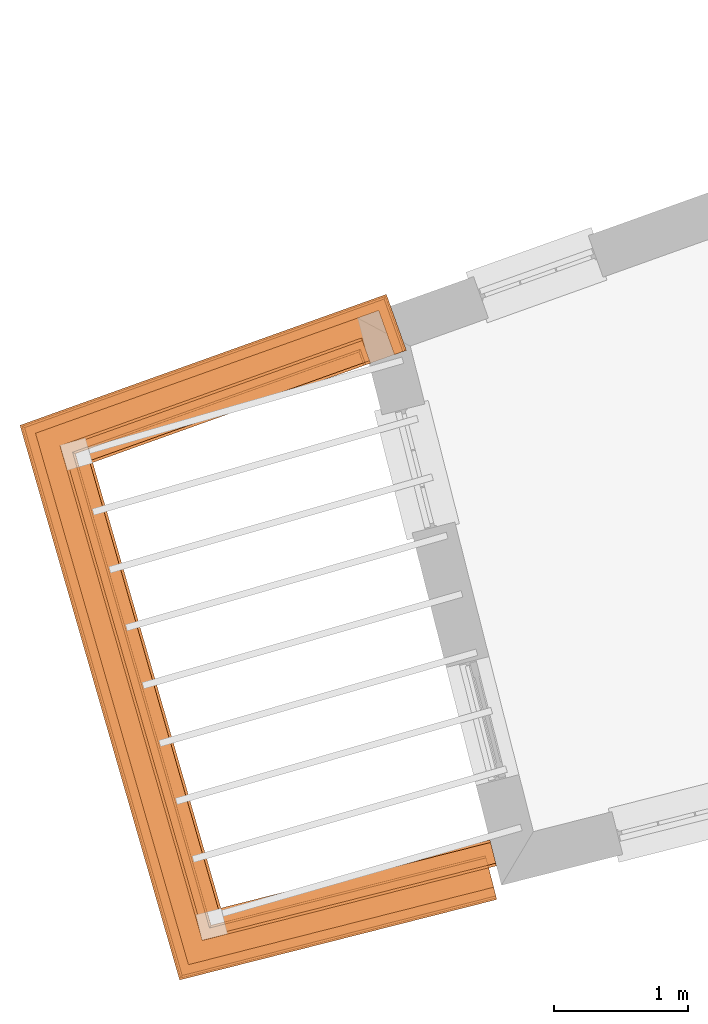
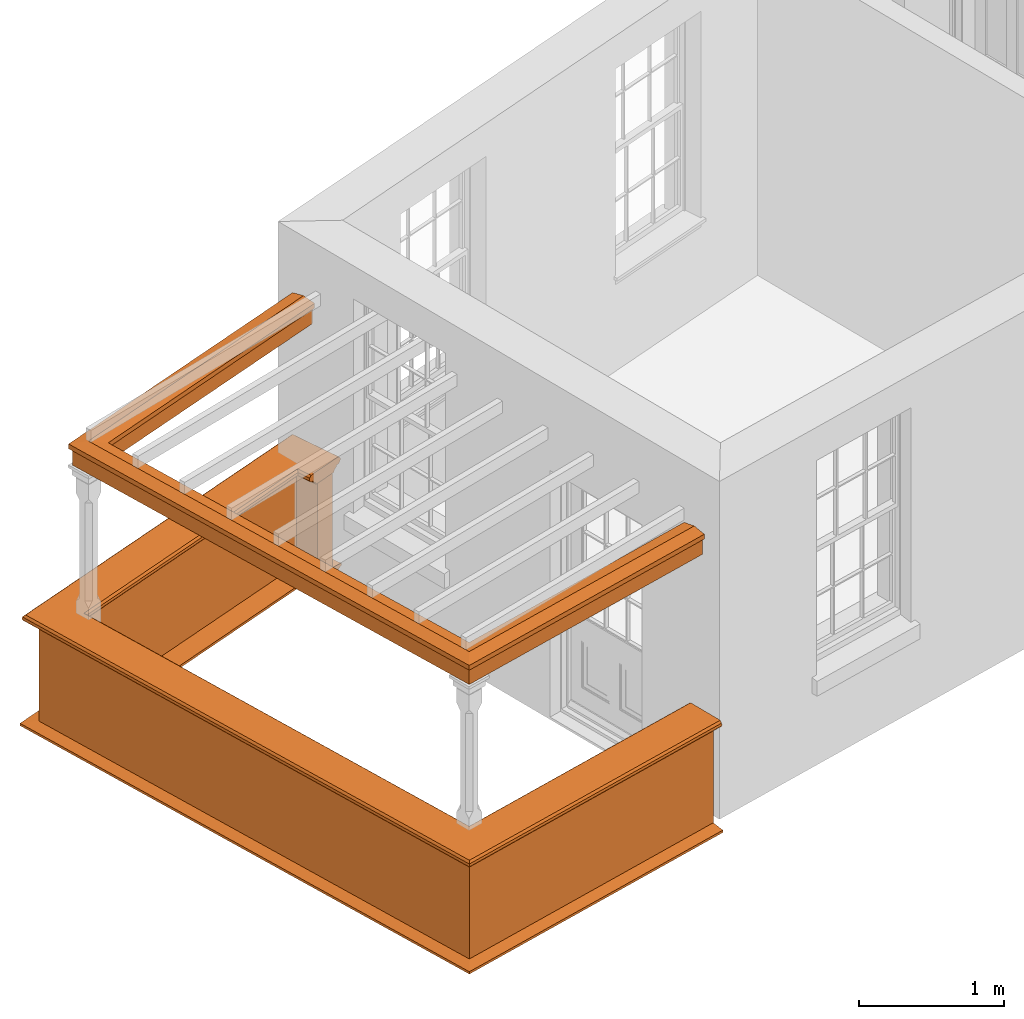
# One storey, part 10 of 11: 5 proxies.
"""IFC2X3 building model written with IfcOpenShell, lengths in metres."""

from ifc_helpers import new_model, entity, si_unit, frame, origin, place, context, subcontext, project, spatial, element, save


model = new_model("IFC2X3")

# Units and contexts
model_context = context("Model", 3, world=origin())
body_context = subcontext(model_context, "Body", "Model", "MODEL_VIEW")
ifc_project = project(units=[si_unit("PLANEANGLEUNIT", "RADIAN"), si_unit("MASSUNIT", "GRAM", prefix="KILO"), si_unit("FORCEUNIT", "NEWTON", prefix="KILO"), si_unit("LENGTHUNIT", "METRE")], contexts=[model_context])

# Site, building, storey
site_placement = place(None, origin())
site = spatial("IfcSite", under=ifc_project, at=site_placement, CompositionType="ELEMENT")
building_placement = place(None, origin())
building = spatial("IfcBuilding", under=site, at=building_placement, Name="Building plot-13", CompositionType="ELEMENT")
storey_placement = place(None, frame((0.0, 0.0, 6.7)))
storey = spatial("IfcBuildingStorey", under=building, at=storey_placement, Name="Floor 1", CompositionType="ELEMENT", Elevation=6.7)

# Proxies
proxy_1_placement = place(storey_placement, origin())
axis2_placement3_d_1 = entity("IfcAxis2Placement3D", entity("IfcCartesianPoint", [0.0, 0.0, 0.0]))
element("IfcBuildingElementProxy", 1, at=proxy_1_placement, inside=storey, Name="parapet", CompositionType="ELEMENT", context=body_context, shape_type="SweptSolid", held_by="IfcProductRepresentation", body=[
    entity("IfcSurfaceCurveSweptAreaSolid", entity("IfcArbitraryClosedProfileDef", "AREA", None, entity("IfcPolyline", [entity("IfcCartesianPoint", [0.0, 0.25]), entity("IfcCartesianPoint", [0.795, 0.25]), entity("IfcCartesianPoint", [0.795, 0.09]), entity("IfcCartesianPoint", [0.02, 0.09]), entity("IfcCartesianPoint", [0.02, -0.08]), entity("IfcCartesianPoint", [0.0, -0.08]), entity("IfcCartesianPoint", [0.0, 0.25])])), axis2_placement3_d_1, entity("IfcPolyline", [entity("IfcCartesianPoint", [65.5529050582027, 47.3924811578515]), entity("IfcCartesianPoint", [65.5192356310196, 47.4866425600987]), entity("IfcCartesianPoint", [63.4113078183222, 46.7329077993252]), entity("IfcCartesianPoint", [64.4222488743234, 43.2198749590139]), entity("IfcCartesianPoint", [66.4683425667329, 43.7388197880005])]), 0.0, 1.0, entity("IfcPlane", axis2_placement3_d_1)),
])
proxy_2_placement = place(storey_placement, origin())
axis2_placement3_d_2 = entity("IfcAxis2Placement3D", entity("IfcCartesianPoint", [0.0, 0.0, 0.0]))
element("IfcBuildingElementProxy", 2, at=proxy_2_placement, inside=storey, Name="parapet", CompositionType="ELEMENT", context=body_context, shape_type="SweptSolid", held_by="IfcProductRepresentation", body=[
    entity("IfcSurfaceCurveSweptAreaSolid", entity("IfcArbitraryClosedProfileDef", "AREA", None, entity("IfcPolyline", [entity("IfcCartesianPoint", [0.795, 0.265]), entity("IfcCartesianPoint", [0.807, 0.268]), entity("IfcCartesianPoint", [0.816, 0.274]), entity("IfcCartesianPoint", [0.822, 0.283]), entity("IfcCartesianPoint", [0.825, 0.295]), entity("IfcCartesianPoint", [0.84, 0.295]), entity("IfcCartesianPoint", [0.84, 0.305]), entity("IfcCartesianPoint", [0.842, 0.317]), entity("IfcCartesianPoint", [0.849, 0.326]), entity("IfcCartesianPoint", [0.858, 0.333]), entity("IfcCartesianPoint", [0.87, 0.335]), entity("IfcCartesianPoint", [0.882, 0.333]), entity("IfcCartesianPoint", [0.891, 0.326]), entity("IfcCartesianPoint", [0.898, 0.317]), entity("IfcCartesianPoint", [0.9, 0.305]), entity("IfcCartesianPoint", [0.9, 0.035]), entity("IfcCartesianPoint", [0.898, 0.023]), entity("IfcCartesianPoint", [0.891, 0.014]), entity("IfcCartesianPoint", [0.882, 0.007]), entity("IfcCartesianPoint", [0.87, 0.005]), entity("IfcCartesianPoint", [0.858, 0.007]), entity("IfcCartesianPoint", [0.849, 0.014]), entity("IfcCartesianPoint", [0.842, 0.023]), entity("IfcCartesianPoint", [0.84, 0.035]), entity("IfcCartesianPoint", [0.84, 0.045]), entity("IfcCartesianPoint", [0.825, 0.045]), entity("IfcCartesianPoint", [0.822, 0.057]), entity("IfcCartesianPoint", [0.816, 0.066]), entity("IfcCartesianPoint", [0.807, 0.072]), entity("IfcCartesianPoint", [0.795, 0.075]), entity("IfcCartesianPoint", [0.795, 0.265])])), axis2_placement3_d_2, entity("IfcPolyline", [entity("IfcCartesianPoint", [65.5529050582027, 47.3924811578515]), entity("IfcCartesianPoint", [65.5192356310196, 47.4866425600987]), entity("IfcCartesianPoint", [63.4113078183222, 46.7329077993252]), entity("IfcCartesianPoint", [64.4222488743234, 43.2198749590139]), entity("IfcCartesianPoint", [66.4683425667329, 43.7388197880005])]), 0.0, 1.0, entity("IfcPlane", axis2_placement3_d_2)),
])
proxy_3_placement = place(storey_placement, origin())
axis2_placement3_d_3 = entity("IfcAxis2Placement3D", entity("IfcCartesianPoint", [0.0, 0.0, 0.0]))
element("IfcBuildingElementProxy", 3, at=proxy_3_placement, inside=storey, Name="parapet", CompositionType="ELEMENT", context=body_context, shape_type="SweptSolid", held_by="IfcProductRepresentation", body=[
    entity("IfcSurfaceCurveSweptAreaSolid", entity("IfcArbitraryClosedProfileDef", "AREA", None, entity("IfcPolyline", [entity("IfcCartesianPoint", [-0.1, 0.25]), entity("IfcCartesianPoint", [-0.1, 0.265]), entity("IfcCartesianPoint", [-0.085, 0.265]), entity("IfcCartesianPoint", [-0.084, 0.278]), entity("IfcCartesianPoint", [-0.081, 0.289]), entity("IfcCartesianPoint", [-0.074, 0.301]), entity("IfcCartesianPoint", [-0.065, 0.309]), entity("IfcCartesianPoint", [-0.055, 0.315]), entity("IfcCartesianPoint", [-0.044, 0.324]), entity("IfcCartesianPoint", [-0.038, 0.334]), entity("IfcCartesianPoint", [-0.035, 0.345]), entity("IfcCartesianPoint", [-0.015, 0.345]), entity("IfcCartesianPoint", [0.0, 0.25]), entity("IfcCartesianPoint", [-0.1, 0.25])])), axis2_placement3_d_3, entity("IfcPolyline", [entity("IfcCartesianPoint", [65.5529050582027, 47.3924811578515]), entity("IfcCartesianPoint", [65.5192356310196, 47.4866425600987]), entity("IfcCartesianPoint", [63.4113078183222, 46.7329077993252]), entity("IfcCartesianPoint", [64.4222488743234, 43.2198749590139]), entity("IfcCartesianPoint", [66.4683425667329, 43.7388197880005])]), 0.0, 1.0, entity("IfcPlane", axis2_placement3_d_3)),
])
proxy_4_placement = place(storey_placement, frame((0.0, 0.0, 2.85)))
axis2_placement3_d_4 = entity("IfcAxis2Placement3D", entity("IfcCartesianPoint", [0.0, 0.0, 0.0]))
element("IfcBuildingElementProxy", 4, at=proxy_4_placement, inside=storey, Name="pergola beam", CompositionType="ELEMENT", context=body_context, shape_type="SweptSolid", held_by="IfcProductRepresentation", body=[
    entity("IfcSurfaceCurveSweptAreaSolid", entity("IfcArbitraryClosedProfileDef", "AREA", None, entity("IfcPolyline", [entity("IfcCartesianPoint", [-0.7, -0.08]), entity("IfcCartesianPoint", [-0.7, 0.08]), entity("IfcCartesianPoint", [-0.56, 0.08]), entity("IfcCartesianPoint", [-0.56, -0.08]), entity("IfcCartesianPoint", [-0.7, -0.08])])), axis2_placement3_d_4, entity("IfcPolyline", [entity("IfcCartesianPoint", [65.5757324723679, 47.5068442164086]), entity("IfcCartesianPoint", [63.4113078183222, 46.7329077993252]), entity("IfcCartesianPoint", [64.4222488743234, 43.2198749590139]), entity("IfcCartesianPoint", [66.5265011434384, 43.7535703797034])]), 0.0, 1.0, entity("IfcPlane", axis2_placement3_d_4)),
])
proxy_5_placement = place(storey_placement, frame((0.0, 0.0, 2.85)))
axis2_placement3_d_5 = entity("IfcAxis2Placement3D", entity("IfcCartesianPoint", [0.0, 0.0, 0.0]))
element("IfcBuildingElementProxy", 5, at=proxy_5_placement, inside=storey, Name="pergola beam", CompositionType="ELEMENT", context=body_context, shape_type="SweptSolid", held_by="IfcProductRepresentation", body=[
    entity("IfcSurfaceCurveSweptAreaSolid", entity("IfcArbitraryClosedProfileDef", "AREA", None, entity("IfcPolyline", [entity("IfcCartesianPoint", [-0.5, 0.0]), entity("IfcCartesianPoint", [-0.52, -0.1]), entity("IfcCartesianPoint", [-0.56, -0.1]), entity("IfcCartesianPoint", [-0.56, 0.1]), entity("IfcCartesianPoint", [-0.52, 0.1]), entity("IfcCartesianPoint", [-0.5, 0.0])])), axis2_placement3_d_5, entity("IfcPolyline", [entity("IfcCartesianPoint", [65.5757324723679, 47.5068442164086]), entity("IfcCartesianPoint", [63.4113078183222, 46.7329077993252]), entity("IfcCartesianPoint", [64.4222488743234, 43.2198749590139]), entity("IfcCartesianPoint", [66.5265011434384, 43.7535703797034])]), 0.0, 1.0, entity("IfcPlane", axis2_placement3_d_5)),
])

save(model, "model.ifc")
